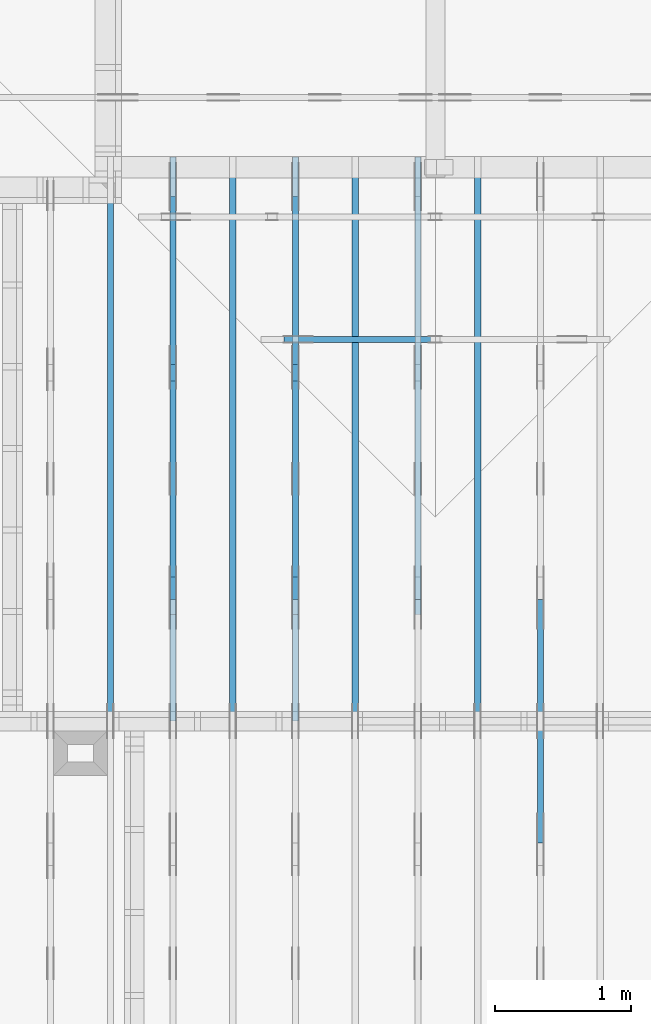
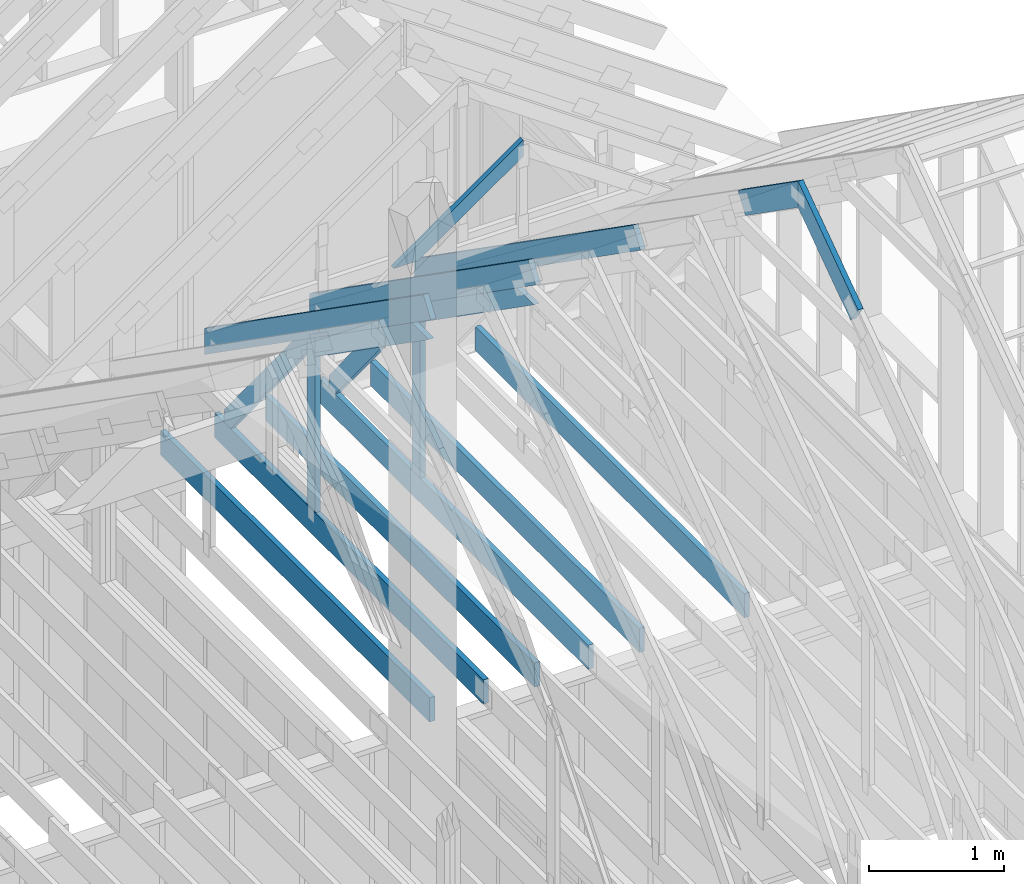
# One storey, part 25 of 70: 18 members, 9 elements without a shape of their own.
"""IFC2X3 building model written with IfcOpenShell, lengths in millimetres."""

from ifc_helpers import new_model, si_unit, frame, origin, origin_with_axes, origin_2d, place, context, project, spatial, faceted_brep, element, aggregate, save


model = new_model("IFC2X3")

# Units and contexts
model_context = context("Model", 3, precision=1e-05, world=origin())
plan_context = context("Plan", 2, precision=1e-05, world=origin_2d())
ifc_project = project(units=[si_unit("LENGTHUNIT", "METRE", prefix="MILLI"), si_unit("AREAUNIT", "SQUARE_METRE"), si_unit("VOLUMEUNIT", "CUBIC_METRE"), si_unit("SOLIDANGLEUNIT", "STERADIAN"), si_unit("PLANEANGLEUNIT", "RADIAN"), si_unit("MASSUNIT", "GRAM"), si_unit("TIMEUNIT", "SECOND"), si_unit("THERMODYNAMICTEMPERATUREUNIT", "DEGREE_CELSIUS"), si_unit("LUMINOUSINTENSITYUNIT", "LUMEN")], contexts=[model_context, plan_context])

# Site, building, storey
site_placement = place(None, origin_with_axes())
site = spatial("IfcSite", under=ifc_project, at=site_placement, CompositionType="ELEMENT")
building_placement = place(site_placement, origin_with_axes())
building = spatial("IfcBuilding", under=site, at=building_placement, Name="Layout 1", CompositionType="ELEMENT")
storey_placement = place(building_placement, origin_with_axes())
storey = spatial("IfcBuildingStorey", under=building, at=storey_placement, Name="Storey 1", CompositionType="ELEMENT", Elevation=0.0)

# Assembly, member
assembly_1_placement = place(storey_placement, frame((7088.750000000147, 8000.0, 1.3776821480501744e-15), z_axis=(-1.0, 1.836909530733566e-16, 6.123031769111886e-17), x_axis=(-1.836909530733566e-16, -1.0, 0.0)))
assembly_1 = element("IfcElementAssembly", 1, at=assembly_1_placement, inside=storey, Name="MB1", AssemblyPlace="FACTORY", PredefinedType="TRUSS")
member_1_placement = place(assembly_1_placement, frame((4000.0000000000005, 219.99999999999997, -45.0), z_axis=(0.0, 0.0, 1.0), x_axis=(-1.0, 1.2246063538223773e-16, 0.0)))
member_1 = element("IfcMember", 2, at=member_1_placement, Name="B3", context=model_context, shape_type="Brep", body=[
    faceted_brep([(4000.0000000000005, 220.00000000000045, 45.0), (0.0, 220.00000000000045, 45.0), (0.0, 0.0, 45.0), (4000.0000000000005, 0.0, 45.0), (0.0, 220.00000000000045, 0.0), (4000.0000000000005, 220.00000000000045, 4.89842541528951e-13), (4000.0000000000005, 0.0, 4.89842541528951e-13), (0.0, 0.0, 0.0), (0.0, 0.0, 0.0), (2.755364296100349e-15, -3.3742366240998092e-31, 45.0), (2.969670408019265e-14, 220.0, 45.0), (2.69413397840923e-14, 220.0, -1.6496267940043512e-30), (4000.0000000000005, -7.347638122934265e-13, 7.283414641863702e-29), (4000.0000000000005, -7.320084479973261e-13, 45.0), (5.061354936149714e-31, 2.755364296100349e-15, 45.0), (0.0, 0.0, 0.0), (4000.0000000000005, 220.00000000000045, 0.0), (4000.0000000000005, 220.00000000000045, 45.0), (4000.0000000000005, 4.547473508864641e-13, 45.0), (4000.0000000000005, 4.547473508864641e-13, 0.0), (0.0, 220.0, 0.0), (0.0, 220.0, 45.0), (4000.0000000000005, 220.00000000000065, 45.0), (4000.0000000000005, 220.00000000000065, 1.1044052673094165e-29)], [[[0, 1, 2, 3]], [[4, 5, 6, 7]], [[8, 9, 10, 11]], [[12, 13, 14, 15]], [[16, 17, 18, 19]], [[20, 21, 22, 23]]]),
])
aggregate(assembly_1, [member_1])

assembly_2_placement = place(storey_placement, frame((7988.750000000147, 8000.0, 1.3776821480501744e-15), z_axis=(-1.0, 1.836909530733566e-16, 6.123031769111886e-17), x_axis=(-1.836909530733566e-16, -1.0, 0.0)))
assembly_2 = element("IfcElementAssembly", 3, at=assembly_2_placement, inside=storey, Name="MB1", AssemblyPlace="FACTORY", PredefinedType="TRUSS")
member_2_placement = place(assembly_2_placement, frame((4000.0000000000005, 219.99999999999997, -45.0), z_axis=(0.0, 0.0, 1.0), x_axis=(-1.0, 1.2246063538223773e-16, 0.0)))
member_2 = element("IfcMember", 4, at=member_2_placement, Name="B3", context=model_context, shape_type="Brep", body=[
    faceted_brep([(4000.0000000000005, 220.00000000000045, 45.0), (0.0, 220.00000000000045, 45.0), (0.0, 0.0, 45.0), (4000.0000000000005, 0.0, 45.0), (0.0, 220.00000000000045, 0.0), (4000.0000000000005, 220.00000000000045, 4.89842541528951e-13), (4000.0000000000005, 0.0, 4.89842541528951e-13), (0.0, 0.0, 0.0), (0.0, 0.0, 0.0), (2.755364296100349e-15, -3.3742366240998092e-31, 45.0), (2.969670408019265e-14, 220.0, 45.0), (2.69413397840923e-14, 220.0, -1.6496267940043512e-30), (4000.0000000000005, -7.347638122934265e-13, 7.283414641863702e-29), (4000.0000000000005, -7.320084479973261e-13, 45.0), (5.061354936149714e-31, 2.755364296100349e-15, 45.0), (0.0, 0.0, 0.0), (4000.0000000000005, 220.00000000000045, 0.0), (4000.0000000000005, 220.00000000000045, 45.0), (4000.0000000000005, 4.547473508864641e-13, 45.0), (4000.0000000000005, 4.547473508864641e-13, 0.0), (0.0, 220.0, 0.0), (0.0, 220.0, 45.0), (4000.0000000000005, 220.00000000000065, 45.0), (4000.0000000000005, 220.00000000000065, 1.1044052673094165e-29)], [[[0, 1, 2, 3]], [[4, 5, 6, 7]], [[8, 9, 10, 11]], [[12, 13, 14, 15]], [[16, 17, 18, 19]], [[20, 21, 22, 23]]]),
])
aggregate(assembly_2, [member_2])

assembly_3_placement = place(storey_placement, frame((8888.750000000146, 8000.0, 1.3776821480501744e-15), z_axis=(-1.0, 1.836909530733566e-16, 6.123031769111886e-17), x_axis=(-1.836909530733566e-16, -1.0, 0.0)))
assembly_3 = element("IfcElementAssembly", 5, at=assembly_3_placement, inside=storey, Name="MB1", AssemblyPlace="FACTORY", PredefinedType="TRUSS")
member_3_placement = place(assembly_3_placement, frame((4000.0000000000005, 219.99999999999997, -45.0), z_axis=(0.0, 0.0, 1.0), x_axis=(-1.0, 1.2246063538223773e-16, 0.0)))
member_3 = element("IfcMember", 6, at=member_3_placement, Name="B3", context=model_context, shape_type="Brep", body=[
    faceted_brep([(4000.0000000000005, 220.00000000000045, 45.0), (0.0, 220.00000000000045, 45.0), (0.0, 0.0, 45.0), (4000.0000000000005, 0.0, 45.0), (0.0, 220.00000000000045, 0.0), (4000.0000000000005, 220.00000000000045, 4.89842541528951e-13), (4000.0000000000005, 0.0, 4.89842541528951e-13), (0.0, 0.0, 0.0), (0.0, 0.0, 0.0), (2.755364296100349e-15, -3.3742366240998092e-31, 45.0), (2.969670408019265e-14, 220.0, 45.0), (2.69413397840923e-14, 220.0, -1.6496267940043512e-30), (4000.0000000000005, -7.347638122934265e-13, 7.283414641863702e-29), (4000.0000000000005, -7.320084479973261e-13, 45.0), (5.061354936149714e-31, 2.755364296100349e-15, 45.0), (0.0, 0.0, 0.0), (4000.0000000000005, 220.00000000000045, 0.0), (4000.0000000000005, 220.00000000000045, 45.0), (4000.0000000000005, 4.547473508864641e-13, 45.0), (4000.0000000000005, 4.547473508864641e-13, 0.0), (0.0, 220.0, 0.0), (0.0, 220.0, 45.0), (4000.0000000000005, 220.00000000000065, 45.0), (4000.0000000000005, 220.00000000000065, 1.1044052673094165e-29)], [[[0, 1, 2, 3]], [[4, 5, 6, 7]], [[8, 9, 10, 11]], [[12, 13, 14, 15]], [[16, 17, 18, 19]], [[20, 21, 22, 23]]]),
])
aggregate(assembly_3, [member_3])

assembly_4_placement = place(storey_placement, frame((9788.750000000146, 8000.0, 1.3776821480501744e-15), z_axis=(-1.0, 1.836909530733566e-16, 6.123031769111886e-17), x_axis=(-1.836909530733566e-16, -1.0, 0.0)))
assembly_4 = element("IfcElementAssembly", 7, at=assembly_4_placement, inside=storey, Name="MB1", AssemblyPlace="FACTORY", PredefinedType="TRUSS")
member_4_placement = place(assembly_4_placement, frame((4000.0000000000005, 219.99999999999997, -45.0), z_axis=(0.0, 0.0, 1.0), x_axis=(-1.0, 1.2246063538223773e-16, 0.0)))
member_4 = element("IfcMember", 8, at=member_4_placement, Name="B3", context=model_context, shape_type="Brep", body=[
    faceted_brep([(4000.0000000000005, 220.00000000000045, 45.0), (0.0, 220.00000000000045, 45.0), (0.0, 0.0, 45.0), (4000.0000000000005, 0.0, 45.0), (0.0, 220.00000000000045, 0.0), (4000.0000000000005, 220.00000000000045, 4.89842541528951e-13), (4000.0000000000005, 0.0, 4.89842541528951e-13), (0.0, 0.0, 0.0), (0.0, 0.0, 0.0), (2.755364296100349e-15, -3.3742366240998092e-31, 45.0), (2.969670408019265e-14, 220.0, 45.0), (2.69413397840923e-14, 220.0, -1.6496267940043512e-30), (4000.0000000000005, -7.347638122934265e-13, 7.283414641863702e-29), (4000.0000000000005, -7.320084479973261e-13, 45.0), (5.061354936149714e-31, 2.755364296100349e-15, 45.0), (0.0, 0.0, 0.0), (4000.0000000000005, 220.00000000000045, 0.0), (4000.0000000000005, 220.00000000000045, 45.0), (4000.0000000000005, 4.547473508864641e-13, 45.0), (4000.0000000000005, 4.547473508864641e-13, 0.0), (0.0, 220.0, 0.0), (0.0, 220.0, 45.0), (4000.0000000000005, 220.00000000000065, 45.0), (4000.0000000000005, 220.00000000000065, 1.1044052673094165e-29)], [[[0, 1, 2, 3]], [[4, 5, 6, 7]], [[8, 9, 10, 11]], [[12, 13, 14, 15]], [[16, 17, 18, 19]], [[20, 21, 22, 23]]]),
])
aggregate(assembly_4, [member_4])

# Assembly, members
assembly_5_placement = place(storey_placement, frame((10250.0, 8000.0, -9.081170196248781e-13), z_axis=(-1.0, 1.836909530733566e-16, 6.123031769111886e-17), x_axis=(-1.836909530733566e-16, -1.0, 0.0)))
assembly_5 = element("IfcElementAssembly", 9, at=assembly_5_placement, inside=storey, Name="T3", AssemblyPlace="FACTORY", PredefinedType="TRUSS")
member_5_placement = place(assembly_5_placement, frame((3888.1525949105694, 3641.0955042035366, -45.00000000000001), z_axis=(0.0, 0.0, 1.0), x_axis=(0.8191520442889916, -0.5735764363510465, 0.0)))
member_5 = element("IfcMember", 10, at=member_5_placement, Name="T18", context=model_context, shape_type="Brep", body=[
    faceted_brep([(1091.5642005560503, 194.99999999996362, 45.0), (0.0, 194.99999999996362, 45.0), (136.54046995208614, 0.0, 45.0), (1091.5642005561149, 0.0, 45.0), (0.0, 194.99999999996362, 0.0), (1091.5642005560503, 194.99999999996362, 1.336736455605983e-13), (1091.5642005561149, 0.0, 1.336736455606062e-13), (136.54046995208614, 0.0, 1.6720832705721806e-14), (136.54046995208614, -2.842170943040401e-14, 3.0619884913871384e-31), (136.54046995208614, -2.842170943040401e-14, 45.0), (1.4210854715202004e-14, 195.00000000170263, 45.0), (1.4210854715202004e-14, 195.00000000170263, -5.932810329456638e-31), (1091.5642005561149, 2.0525182992035534e-09, 1.2934457505131873e-29), (1091.5642005561149, 2.0525210545678495e-09, 45.0), (136.54046995208614, -2.3668346958569874e-14, 45.0), (136.54046995208614, -2.6423711254670222e-14, 1.6179322347011683e-30), (1091.5642005561149, 194.99999999996362, 3.950615413346827e-27), (1091.5642005561149, 194.99999999996362, 45.0), (1091.5642005561149, 2.052729541901499e-09, 45.0), (1091.5642005561149, 2.052729541901499e-09, 0.0), (0.0, 195.00000000170257, 0.0), (0.0, 195.00000000170257, 45.0), (1091.5642005560503, 194.9999999999637, 45.0), (1091.5642005560503, 194.9999999999637, 6.310887241768095e-30)], [[[0, 1, 2, 3]], [[4, 5, 6, 7]], [[8, 9, 10, 11]], [[12, 13, 14, 15]], [[16, 17, 18, 19]], [[20, 21, 22, 23]]]),
])
member_6_placement = place(assembly_5_placement, frame((3217.690358731264, 3015.0000000002183, -45.00000000000001), z_axis=(0.0, 0.0, 1.0), x_axis=(0.8191520442889918, 0.5735764363510462, 0.0)))
member_6 = element("IfcMember", 11, at=member_6_placement, Name="T18", context=model_context, shape_type="Brep", body=[
    faceted_brep([(1091.564200553914, 194.99999999865213, 45.0), (0.0, 194.99999999865213, 45.0), (1.6370904631912708e-10, 7.557900971733034e-10, 45.0), (955.0237306039635, 7.557900971733034e-10, 45.0), (0.0, 194.99999999865213, 0.0), (1091.564200553914, 194.99999999865213, 1.3367364556033665e-13), (955.0237306039635, 7.557900971733034e-10, 1.169528128548764e-13), (1.6370904631912708e-10, 7.557900971733034e-10, 2.004791383006049e-26), (1.6370904631912732e-10, 7.557900971733033e-10, -1.4349296274686127e-41), (1.6371180168342342e-10, 7.557900971733033e-10, 45.0), (6.660321774678196e-14, 194.99999999996407, 45.0), (6.384785345068161e-14, 194.99999999996407, -3.909424350681179e-30), (955.0237306039635, -1.5956987698560245e-13, 9.770514261762543e-30), (955.0237306039635, -1.568145126895021e-13, 45.0), (1.6370904631912708e-10, 7.557928525375995e-10, 45.0), (1.6370904631912708e-10, 7.557900971733034e-10, 0.0), (1091.564200553914, 194.99999999865213, 0.0), (1091.564200553914, 194.99999999865213, 45.0), (955.0237306039635, -5.684341886080802e-14, 45.0), (955.0237306039635, -5.684341886080802e-14, -6.310887241768095e-30), (0.0, 194.99999999996407, 0.0), (0.0, 194.99999999996407, 45.0), (1091.564200553914, 194.99999999865202, 45.0), (1091.564200553914, 194.99999999865202, -6.310887241768095e-30)], [[[0, 1, 2, 3]], [[4, 5, 6, 7]], [[8, 9, 10, 11]], [[12, 13, 14, 15]], [[16, 17, 18, 19]], [[20, 21, 22, 23]]]),
])
aggregate(assembly_5, [member_5, member_6])

# Assembly, member
assembly_6_placement = place(storey_placement, frame((9350.0, 8000.0, -9.081170196248781e-13), z_axis=(-1.0, 1.836909530733566e-16, 6.123031769111886e-17), x_axis=(-1.836909530733566e-16, -1.0, 0.0)))
assembly_6 = element("IfcElementAssembly", 12, at=assembly_6_placement, inside=storey, Name="T3", AssemblyPlace="FACTORY", PredefinedType="TRUSS")
member_7_placement = place(assembly_6_placement, frame((-145.0000000000008, 660.4188621509819, -45.0), z_axis=(0.0, 0.0, 1.0), x_axis=(0.8191520442889915, 0.5735764363510465, 0.0)))
member_7 = element("IfcMember", 13, at=member_7_placement, Name="T10", context=model_context, shape_type="Brep", body=[
    faceted_brep([(4105.08693981286, 195.00000000242483, 45.0), (136.5404699510177, 195.00000000242483, 45.0), (0.0, 0.0, 45.0), (4105.08693981249, 0.0, 45.0), (136.5404699510177, 195.00000000242483, 1.6720832705590965e-14), (4105.08693981286, 195.00000000242483, 5.027115549488087e-13), (4105.08693981249, 0.0, 5.027115549487634e-13), (0.0, 0.0, 0.0), (-1.1640850691051581e-14, 8.151011405048023e-15, 8.701351488741532e-31), (-9.383788395140082e-15, 6.570599371241877e-15, 45.0), (136.54046995101766, 195.00000000017752, 45.0), (136.54046995101766, 195.00000000017752, 4.814439674979212e-30), (4105.08693981249, 2.4530373342863473e-09, 2.683789629641233e-29), (4105.08693981249, 2.4530400896506434e-09, 45.0), (-1.646496550984743e-27, 2.755364296100349e-15, 45.0), (0.0, 0.0, 0.0), (4105.08693981249, 195.00000000242483, -2.2668706972430995e-26), (4105.08693981249, 195.00000000242483, 45.0), (4105.08693981249, 2.4534756448701955e-09, 45.0), (4105.08693981249, 2.4534756448701955e-09, 0.0), (136.5404699510177, 195.00000000017747, 0.0), (136.5404699510177, 195.00000000017747, 45.0), (4105.08693981286, 195.00000000242514, 45.0), (4105.08693981286, 195.00000000242514, 1.8932661725304283e-29)], [[[0, 1, 2, 3]], [[4, 5, 6, 7]], [[8, 9, 10, 11]], [[12, 13, 14, 15]], [[16, 17, 18, 19]], [[20, 21, 22, 23]]]),
])
aggregate(assembly_6, [member_7])

# Assembly, members
assembly_7_placement = place(storey_placement, frame((8450.0, 8000.0, -9.081170196248781e-13), z_axis=(-1.0, 1.836909530733566e-16, 6.123031769111886e-17), x_axis=(-1.836909530733566e-16, -1.0, 0.0)))
assembly_7 = element("IfcElementAssembly", 14, at=assembly_7_placement, inside=storey, Name="T3", AssemblyPlace="FACTORY", PredefinedType="TRUSS")
member_8_placement = place(assembly_7_placement, frame((-145.0000000000008, 660.4188621509819, -45.0), z_axis=(0.0, 0.0, 1.0), x_axis=(0.8191520442889915, 0.5735764363510465, 0.0)))
member_8 = element("IfcMember", 15, at=member_8_placement, Name="T10", context=model_context, shape_type="Brep", body=[
    faceted_brep([(4105.08693981286, 195.00000000242483, 45.0), (136.5404699510177, 195.00000000242483, 45.0), (0.0, 0.0, 45.0), (4105.08693981249, 0.0, 45.0), (136.5404699510177, 195.00000000242483, 1.6720832705590965e-14), (4105.08693981286, 195.00000000242483, 5.027115549488087e-13), (4105.08693981249, 0.0, 5.027115549487634e-13), (0.0, 0.0, 0.0), (-1.1640850691051581e-14, 8.151011405048023e-15, 8.701351488741532e-31), (-9.383788395140082e-15, 6.570599371241877e-15, 45.0), (136.54046995101766, 195.00000000017752, 45.0), (136.54046995101766, 195.00000000017752, 4.814439674979212e-30), (4105.08693981249, 2.4530373342863473e-09, 2.683789629641233e-29), (4105.08693981249, 2.4530400896506434e-09, 45.0), (-1.646496550984743e-27, 2.755364296100349e-15, 45.0), (0.0, 0.0, 0.0), (4105.08693981249, 195.00000000242483, -2.2668706972430995e-26), (4105.08693981249, 195.00000000242483, 45.0), (4105.08693981249, 2.4534756448701955e-09, 45.0), (4105.08693981249, 2.4534756448701955e-09, 0.0), (136.5404699510177, 195.00000000017747, 0.0), (136.5404699510177, 195.00000000017747, 45.0), (4105.08693981286, 195.00000000242514, 45.0), (4105.08693981286, 195.00000000242514, 1.8932661725304283e-29)], [[[0, 1, 2, 3]], [[4, 5, 6, 7]], [[8, 9, 10, 11]], [[12, 13, 14, 15]], [[16, 17, 18, 19]], [[20, 21, 22, 23]]]),
])
member_9_placement = place(assembly_7_placement, frame((3999.9999999999995, 220.0, -45.0), z_axis=(0.0, 0.0, 1.0), x_axis=(-1.0, 1.2246063538223773e-16, 0.0)))
member_9 = element("IfcMember", 16, at=member_9_placement, Name="B3", context=model_context, shape_type="Brep", body=[
    faceted_brep([(3999.9999999999995, 220.00000000000048, 45.0), (0.0, 220.00000000000048, 45.0), (0.0, 0.0, 45.0), (4000.0, 0.0, 45.0), (0.0, 220.00000000000048, 0.0), (3999.9999999999995, 220.00000000000048, 4.898425415289508e-13), (4000.0, 0.0, 4.898425415289509e-13), (0.0, 0.0, 0.0), (0.0, 0.0, 0.0), (2.755364296100349e-15, -3.3742366240998092e-31, 45.0), (2.969670408019265e-14, 220.0, 45.0), (2.69413397840923e-14, 220.0, -1.6496267940043512e-30), (4000.0, -7.347638122934264e-13, 7.457441671638533e-29), (4000.0, -7.32008447997326e-13, 45.0), (5.061354936149714e-31, 2.755364296100349e-15, 45.0), (0.0, 0.0, 0.0), (4000.0, 220.00000000000048, 5.048709793414476e-29), (4000.0, 220.00000000000048, 45.0), (4000.0, 4.831690603168681e-13, 45.0), (4000.0, 4.831690603168681e-13, 0.0), (0.0, 220.0, 0.0), (0.0, 220.0, 45.0), (3999.9999999999995, 220.00000000000065, 45.0), (3999.9999999999995, 220.00000000000065, 9.466330862652142e-30)], [[[0, 1, 2, 3]], [[4, 5, 6, 7]], [[8, 9, 10, 11]], [[12, 13, 14, 15]], [[16, 17, 18, 19]], [[20, 21, 22, 23]]]),
])
member_10_placement = place(assembly_7_placement, frame((1500.000000004151, 1635.2479181252359, -45.0), z_axis=(0.0, 0.0, 1.0), x_axis=(0.8191520442886487, 0.5735764363515361, 0.0)))
member_10 = element("IfcMember", 17, at=member_10_placement, Name="SC5", context=model_context, shape_type="Brep", body=[
    faceted_brep([(1858.470759764839, 145.00000000273417, 45.0), (101.53009304261923, 145.00000000273417, 45.0), (0.0, 4.395587893668562e-09, 45.0), (2065.5522207463405, 4.395587893668562e-09, 45.0), (101.53009304261923, 145.00000000273417, 1.2433439704416865e-14), (1858.470759764839, 145.00000000273417, 2.2758951008011226e-13), (2065.5522207463405, 4.395587893668562e-09, 2.52948837367789e-13), (0.0, 4.395587893668562e-09, 0.0), (8.6935104615022825e-16, 4.395587284942406e-09, -6.498261357111438e-32), (3.1264133420566933e-15, 4.395585704530372e-09, 45.0), (101.5300930426192, 145.00000000701368, 45.0), (101.5300930426192, 145.00000000701368, 1.9667596592082453e-30), (2065.5522207463405, -4.425913119322423e-13, 2.71000066369662e-29), (2065.5522207463405, -4.3983594763614193e-13, 45.0), (5.864129370369717e-27, 4.395590649032858e-09, 45.0), (0.0, 4.395587893668562e-09, 0.0), (1858.470759764839, 145.00000000273428, 0.0), (1858.470759764839, 145.00000000273428, 45.0), (2065.552220746341, -1.1368683772161603e-13, 45.0), (2065.552220746341, -1.1368683772161603e-13, 0.0), (101.53009304261923, 145.00000000701368, 1.5777218104420236e-30), (101.53009304261923, 145.00000000701368, 45.0), (1858.470759764839, 145.00000000273437, 45.0), (1858.470759764839, 145.00000000273437, 1.262177448353619e-29)], [[[0, 1, 2, 3]], [[4, 5, 6, 7]], [[8, 9, 10, 11]], [[12, 13, 14, 15]], [[16, 17, 18, 19]], [[20, 21, 22, 23]]]),
])
member_11_placement = place(assembly_7_placement, frame((1380.0000000018192, 1812.2602625085638, -45.0), z_axis=(0.0, 0.0, 1.0), x_axis=(-1.836909530733566e-16, -1.0, 0.0)))
member_11 = element("IfcMember", 18, at=member_11_placement, Name="R1", context=model_context, shape_type="Brep", body=[
    faceted_brep([(1592.2602625085638, 120.00000000001455, 45.0), (0.0, 120.00000000001455, 45.0), (84.02490458526881, 1.432454155292362e-11, 45.0), (1592.2602625085638, 1.432454155292362e-11, 45.0), (0.0, 120.00000000001455, 0.0), (1592.2602625085638, 120.00000000001455, 1.9498920344068735e-13), (1592.2602625085638, 1.432454155292362e-11, 1.9498920344068735e-13), (84.02490458526881, 1.432454155292362e-11, 1.0289743203443919e-14), (84.0249045852688, 1.4303225270850817e-11, 1.5777218104420236e-30), (84.02490458526881, 1.4303225270850817e-11, 45.0), (2.1316282072803006e-14, 120.00000000001435, 45.0), (2.1316282072803006e-14, 120.00000000001435, -2.3665827156630354e-30), (1592.2602625085638, -7.262347142616226e-13, 4.446758227255812e-29), (1592.2602625085638, -7.234793499655223e-13, 45.0), (84.02490458526881, 1.4288972904488156e-11, 45.0), (84.02490458526881, 1.4286217540192056e-11, 2.3465914747521543e-30), (1592.2602625085638, 120.00000000001455, 0.0), (1592.2602625085638, 120.00000000001455, 45.0), (1592.2602625085638, 0.0, 45.0), (1592.2602625085638, 0.0, 0.0), (0.0, 120.00000000001432, 0.0), (0.0, 120.00000000001432, 45.0), (1592.2602625085638, 120.00000000001458, 45.0), (1592.2602625085638, 120.00000000001458, 1.5777218104420236e-30)], [[[0, 1, 2, 3]], [[4, 5, 6, 7]], [[8, 9, 10, 11]], [[12, 13, 14, 15]], [[16, 17, 18, 19]], [[20, 21, 22, 23]]]),
])
member_12_placement = place(assembly_7_placement, frame((1323.9061318638364, 1774.1671329521819, -45.0), z_axis=(0.0, 0.0, 1.0), x_axis=(-0.6335417245359891, -0.7737085260432154, 0.0)))
member_12 = element("IfcMember", 19, at=member_12_placement, Name="W6", context=model_context, shape_type="Brep", body=[
    faceted_brep([(1889.9928508901896, 145.00000000000045, 45.0), (88.54013234780132, 145.00000000000045, 45.0), (0.0, 72.4999999998246, 45.0), (258.1329393158155, 1.0373923942097463e-12, 45.0), (1860.818453163112, 1.0373923942097463e-12, 45.0), (1949.358585509489, 72.4999999998246, 45.0), (88.54013234780132, 145.00000000000045, 1.0842680864139169e-14), (1889.9928508901896, 145.00000000000045, 2.314497253878995e-13), (1949.358585509489, 72.4999999998246, 2.387196909693122e-13), (1860.818453163112, 1.0373923942097463e-12, 2.278770101053475e-13), (258.1329393158155, 1.0373923942097463e-12, 3.161112376169938e-14), (0.0, 72.4999999998246, 0.0), (1.4210854715202004e-14, 72.49999999982458, -1.1832913578315177e-30), (1.4210854715202004e-14, 72.49999999982458, 45.0), (88.54013234780135, 145.00000000000057, 45.0), (88.54013234780135, 145.00000000000057, -7.888609052210118e-31), (258.13293931581546, 9.094947017729282e-13, 9.44327198188855e-30), (258.13293931581546, 9.094947017729282e-13, 45.0), (0.0, 72.49999999982461, 45.0), (0.0, 72.49999999982461, -8.492704648594505e-31), (1860.818453163112, -7.900766401995888e-13, 4.837664367975264e-29), (1860.818453163112, -7.873212759034885e-13, 45.0), (258.1329393158155, 9.305482405771586e-13, 45.0), (258.1329393158155, 9.277928762810583e-13, 6.710813301567046e-30), (1949.3585855094898, 72.4999999985605, 7.573064690121713e-29), (1949.3585855094898, 72.4999999985605, 45.0), (1860.8184531631127, -7.958078640513122e-13, 45.0), (1860.8184531631127, -7.958078640513122e-13, 6.310887241768094e-29), (1889.9928508901896, 145.00000000000057, 1.262177448353619e-29), (1889.9928508901896, 145.00000000000057, 45.0), (1949.358585509489, 72.49999999856152, 45.0), (1949.358585509489, 72.49999999856152, 1.262177448353619e-29), (88.54013234780132, 145.00000000000057, 0.0), (88.54013234780132, 145.00000000000057, 45.0), (1889.9928508901896, 145.00000000000045, 45.0), (1889.9928508901896, 145.00000000000045, 0.0)], [[[0, 1, 2, 3, 4, 5]], [[6, 7, 8, 9, 10, 11]], [[12, 13, 14, 15]], [[16, 17, 18, 19]], [[20, 21, 22, 23]], [[24, 25, 26, 27]], [[28, 29, 30, 31]], [[32, 33, 34, 35]]]),
])
aggregate(assembly_7, [member_8, member_9, member_10, member_11, member_12])

assembly_8_placement = place(storey_placement, frame((7550.000000000001, 8000.0, -9.081170196248781e-13), z_axis=(-1.0, 1.836909530733566e-16, 6.123031769111886e-17), x_axis=(-1.836909530733566e-16, -1.0, 0.0)))
assembly_8 = element("IfcElementAssembly", 20, at=assembly_8_placement, inside=storey, Name="T3", AssemblyPlace="FACTORY", PredefinedType="TRUSS")
member_13_placement = place(assembly_8_placement, frame((-145.0000000000008, 660.4188621509819, -45.0), z_axis=(0.0, 0.0, 1.0), x_axis=(0.8191520442889915, 0.5735764363510465, 0.0)))
member_13 = element("IfcMember", 21, at=member_13_placement, Name="T10", context=model_context, shape_type="Brep", body=[
    faceted_brep([(4105.08693981286, 195.00000000242483, 45.0), (136.5404699510177, 195.00000000242483, 45.0), (0.0, 0.0, 45.0), (4105.08693981249, 0.0, 45.0), (136.5404699510177, 195.00000000242483, 1.6720832705590965e-14), (4105.08693981286, 195.00000000242483, 5.027115549488087e-13), (4105.08693981249, 0.0, 5.027115549487634e-13), (0.0, 0.0, 0.0), (-1.1640850691051581e-14, 8.151011405048023e-15, 8.701351488741532e-31), (-9.383788395140082e-15, 6.570599371241877e-15, 45.0), (136.54046995101766, 195.00000000017752, 45.0), (136.54046995101766, 195.00000000017752, 4.814439674979212e-30), (4105.08693981249, 2.4530373342863473e-09, 2.683789629641233e-29), (4105.08693981249, 2.4530400896506434e-09, 45.0), (-1.646496550984743e-27, 2.755364296100349e-15, 45.0), (0.0, 0.0, 0.0), (4105.08693981249, 195.00000000242483, -2.2668706972430995e-26), (4105.08693981249, 195.00000000242483, 45.0), (4105.08693981249, 2.4534756448701955e-09, 45.0), (4105.08693981249, 2.4534756448701955e-09, 0.0), (136.5404699510177, 195.00000000017747, 0.0), (136.5404699510177, 195.00000000017747, 45.0), (4105.08693981286, 195.00000000242514, 45.0), (4105.08693981286, 195.00000000242514, 1.8932661725304283e-29)], [[[0, 1, 2, 3]], [[4, 5, 6, 7]], [[8, 9, 10, 11]], [[12, 13, 14, 15]], [[16, 17, 18, 19]], [[20, 21, 22, 23]]]),
])
member_14_placement = place(assembly_8_placement, frame((3999.9999999999995, 220.0, -45.0), z_axis=(0.0, 0.0, 1.0), x_axis=(-1.0, 1.2246063538223773e-16, 0.0)))
member_14 = element("IfcMember", 22, at=member_14_placement, Name="B3", context=model_context, shape_type="Brep", body=[
    faceted_brep([(3999.9999999999995, 220.00000000000048, 45.0), (0.0, 220.00000000000048, 45.0), (0.0, 0.0, 45.0), (4000.0, 0.0, 45.0), (0.0, 220.00000000000048, 0.0), (3999.9999999999995, 220.00000000000048, 4.898425415289508e-13), (4000.0, 0.0, 4.898425415289509e-13), (0.0, 0.0, 0.0), (0.0, 0.0, 0.0), (2.755364296100349e-15, -3.3742366240998092e-31, 45.0), (2.969670408019265e-14, 220.0, 45.0), (2.69413397840923e-14, 220.0, -1.6496267940043512e-30), (4000.0, -7.347638122934264e-13, 7.457441671638533e-29), (4000.0, -7.32008447997326e-13, 45.0), (5.061354936149714e-31, 2.755364296100349e-15, 45.0), (0.0, 0.0, 0.0), (4000.0, 220.00000000000048, 5.048709793414476e-29), (4000.0, 220.00000000000048, 45.0), (4000.0, 4.831690603168681e-13, 45.0), (4000.0, 4.831690603168681e-13, 0.0), (0.0, 220.0, 0.0), (0.0, 220.0, 45.0), (3999.9999999999995, 220.00000000000065, 45.0), (3999.9999999999995, 220.00000000000065, 9.466330862652142e-30)], [[[0, 1, 2, 3]], [[4, 5, 6, 7]], [[8, 9, 10, 11]], [[12, 13, 14, 15]], [[16, 17, 18, 19]], [[20, 21, 22, 23]]]),
])
member_15_placement = place(assembly_8_placement, frame((1500.000000004151, 1635.2479181252359, -45.0), z_axis=(0.0, 0.0, 1.0), x_axis=(0.8191520442886487, 0.5735764363515361, 0.0)))
member_15 = element("IfcMember", 23, at=member_15_placement, Name="SC5", context=model_context, shape_type="Brep", body=[
    faceted_brep([(1858.470759764839, 145.00000000273417, 45.0), (101.53009304261923, 145.00000000273417, 45.0), (0.0, 4.395587893668562e-09, 45.0), (2065.5522207463405, 4.395587893668562e-09, 45.0), (101.53009304261923, 145.00000000273417, 1.2433439704416865e-14), (1858.470759764839, 145.00000000273417, 2.2758951008011226e-13), (2065.5522207463405, 4.395587893668562e-09, 2.52948837367789e-13), (0.0, 4.395587893668562e-09, 0.0), (8.6935104615022825e-16, 4.395587284942406e-09, -6.498261357111438e-32), (3.1264133420566933e-15, 4.395585704530372e-09, 45.0), (101.5300930426192, 145.00000000701368, 45.0), (101.5300930426192, 145.00000000701368, 1.9667596592082453e-30), (2065.5522207463405, -4.425913119322423e-13, 2.71000066369662e-29), (2065.5522207463405, -4.3983594763614193e-13, 45.0), (5.864129370369717e-27, 4.395590649032858e-09, 45.0), (0.0, 4.395587893668562e-09, 0.0), (1858.470759764839, 145.00000000273428, 0.0), (1858.470759764839, 145.00000000273428, 45.0), (2065.552220746341, -1.1368683772161603e-13, 45.0), (2065.552220746341, -1.1368683772161603e-13, 0.0), (101.53009304261923, 145.00000000701368, 1.5777218104420236e-30), (101.53009304261923, 145.00000000701368, 45.0), (1858.470759764839, 145.00000000273437, 45.0), (1858.470759764839, 145.00000000273437, 1.262177448353619e-29)], [[[0, 1, 2, 3]], [[4, 5, 6, 7]], [[8, 9, 10, 11]], [[12, 13, 14, 15]], [[16, 17, 18, 19]], [[20, 21, 22, 23]]]),
])
member_16_placement = place(assembly_8_placement, frame((1380.0000000018192, 1812.2602625085638, -45.0), z_axis=(0.0, 0.0, 1.0), x_axis=(-1.836909530733566e-16, -1.0, 0.0)))
member_16 = element("IfcMember", 24, at=member_16_placement, Name="R1", context=model_context, shape_type="Brep", body=[
    faceted_brep([(1592.2602625085638, 120.00000000001455, 45.0), (0.0, 120.00000000001455, 45.0), (84.02490458526881, 1.432454155292362e-11, 45.0), (1592.2602625085638, 1.432454155292362e-11, 45.0), (0.0, 120.00000000001455, 0.0), (1592.2602625085638, 120.00000000001455, 1.9498920344068735e-13), (1592.2602625085638, 1.432454155292362e-11, 1.9498920344068735e-13), (84.02490458526881, 1.432454155292362e-11, 1.0289743203443919e-14), (84.0249045852688, 1.4303225270850817e-11, 1.5777218104420236e-30), (84.02490458526881, 1.4303225270850817e-11, 45.0), (2.1316282072803006e-14, 120.00000000001435, 45.0), (2.1316282072803006e-14, 120.00000000001435, -2.3665827156630354e-30), (1592.2602625085638, -7.262347142616226e-13, 4.446758227255812e-29), (1592.2602625085638, -7.234793499655223e-13, 45.0), (84.02490458526881, 1.4288972904488156e-11, 45.0), (84.02490458526881, 1.4286217540192056e-11, 2.3465914747521543e-30), (1592.2602625085638, 120.00000000001455, 0.0), (1592.2602625085638, 120.00000000001455, 45.0), (1592.2602625085638, 0.0, 45.0), (1592.2602625085638, 0.0, 0.0), (0.0, 120.00000000001432, 0.0), (0.0, 120.00000000001432, 45.0), (1592.2602625085638, 120.00000000001458, 45.0), (1592.2602625085638, 120.00000000001458, 1.5777218104420236e-30)], [[[0, 1, 2, 3]], [[4, 5, 6, 7]], [[8, 9, 10, 11]], [[12, 13, 14, 15]], [[16, 17, 18, 19]], [[20, 21, 22, 23]]]),
])
member_17_placement = place(assembly_8_placement, frame((1323.9061318638364, 1774.1671329521819, -45.0), z_axis=(0.0, 0.0, 1.0), x_axis=(-0.6335417245359891, -0.7737085260432154, 0.0)))
member_17 = element("IfcMember", 25, at=member_17_placement, Name="W6", context=model_context, shape_type="Brep", body=[
    faceted_brep([(1889.9928508901896, 145.00000000000045, 45.0), (88.54013234780132, 145.00000000000045, 45.0), (0.0, 72.4999999998246, 45.0), (258.1329393158155, 1.0373923942097463e-12, 45.0), (1860.818453163112, 1.0373923942097463e-12, 45.0), (1949.358585509489, 72.4999999998246, 45.0), (88.54013234780132, 145.00000000000045, 1.0842680864139169e-14), (1889.9928508901896, 145.00000000000045, 2.314497253878995e-13), (1949.358585509489, 72.4999999998246, 2.387196909693122e-13), (1860.818453163112, 1.0373923942097463e-12, 2.278770101053475e-13), (258.1329393158155, 1.0373923942097463e-12, 3.161112376169938e-14), (0.0, 72.4999999998246, 0.0), (1.4210854715202004e-14, 72.49999999982458, -1.1832913578315177e-30), (1.4210854715202004e-14, 72.49999999982458, 45.0), (88.54013234780135, 145.00000000000057, 45.0), (88.54013234780135, 145.00000000000057, -7.888609052210118e-31), (258.13293931581546, 9.094947017729282e-13, 9.44327198188855e-30), (258.13293931581546, 9.094947017729282e-13, 45.0), (0.0, 72.49999999982461, 45.0), (0.0, 72.49999999982461, -8.492704648594505e-31), (1860.818453163112, -7.900766401995888e-13, 4.837664367975264e-29), (1860.818453163112, -7.873212759034885e-13, 45.0), (258.1329393158155, 9.305482405771586e-13, 45.0), (258.1329393158155, 9.277928762810583e-13, 6.710813301567046e-30), (1949.3585855094898, 72.4999999985605, 7.573064690121713e-29), (1949.3585855094898, 72.4999999985605, 45.0), (1860.8184531631127, -7.958078640513122e-13, 45.0), (1860.8184531631127, -7.958078640513122e-13, 6.310887241768094e-29), (1889.9928508901896, 145.00000000000057, 1.262177448353619e-29), (1889.9928508901896, 145.00000000000057, 45.0), (1949.358585509489, 72.49999999856152, 45.0), (1949.358585509489, 72.49999999856152, 1.262177448353619e-29), (88.54013234780132, 145.00000000000057, 0.0), (88.54013234780132, 145.00000000000057, 45.0), (1889.9928508901896, 145.00000000000045, 45.0), (1889.9928508901896, 145.00000000000045, 0.0)], [[[0, 1, 2, 3, 4, 5]], [[6, 7, 8, 9, 10, 11]], [[12, 13, 14, 15]], [[16, 17, 18, 19]], [[20, 21, 22, 23]], [[24, 25, 26, 27]], [[28, 29, 30, 31]], [[32, 33, 34, 35]]]),
])
aggregate(assembly_8, [member_13, member_14, member_15, member_16, member_17])

# Assembly, member
assembly_9_placement = place(storey_placement, frame((8194.999999999996, 6782.5, 1836.748008160603), z_axis=(0.0, -1.0, 6.123031769111886e-17), x_axis=(1.0, 0.0, 0.0)))
assembly_9 = element("IfcElementAssembly", 26, at=assembly_9_placement, inside=storey, Name="SB2", AssemblyPlace="FACTORY", PredefinedType="TRUSS")
member_18_placement = place(assembly_9_placement, frame((262.7069331712677, 37.45642429471425, -45.0), z_axis=(0.0, 0.0, 1.0), x_axis=(0.8191520442889915, 0.5735764363510465, 0.0)))
member_18 = element("IfcMember", 27, at=member_18_placement, Name="T21", context=model_context, shape_type="Brep", body=[
    faceted_brep([(1356.429794611683, 119.9999999996475, 45.0), (0.0, 119.9999999996475, 45.0), (171.37776080961953, 0.0, 45.0), (1272.4048900273456, 0.0, 45.0), (0.0, 119.9999999996475, 0.0), (1356.429794611683, 119.9999999996475, 1.6610925449954493e-13), (1272.4048900273456, 0.0, 1.5581951129621505e-13), (171.37776080961953, 0.0, 2.0987029479131167e-14), (171.37776080961953, -2.842170943040401e-14, 1.5777218104420236e-30), (171.37776080961953, -2.842170943040401e-14, 45.0), (7.105427357601002e-15, 120.00000000039621, 45.0), (7.105427357601002e-15, 120.00000000039621, -7.888609052210118e-31), (1272.4048900273456, 8.29031465531182e-10, 1.4876602143082615e-29), (1272.4048900273456, 8.290342208954781e-10, 45.0), (171.37776080961953, -2.9968634675889615e-14, 45.0), (171.37776080961953, -3.2723998971989964e-14, 2.0037008531779553e-30), (1356.4297946116835, 119.99999999964712, 2.524354896707238e-29), (1356.4297946116835, 119.99999999964712, 45.0), (1272.4048900273458, 8.288907338283025e-10, 45.0), (1272.4048900273458, 8.288907338283025e-10, 1.262177448353619e-29), (0.0, 120.0000000003962, 0.0), (0.0, 120.0000000003962, 45.0), (1356.429794611683, 119.99999999964736, 45.0), (1356.429794611683, 119.99999999964736, -9.466330862652142e-30)], [[[0, 1, 2, 3]], [[4, 5, 6, 7]], [[8, 9, 10, 11]], [[12, 13, 14, 15]], [[16, 17, 18, 19]], [[20, 21, 22, 23]]]),
])
aggregate(assembly_9, [member_18])

save(model, "model.ifc")
